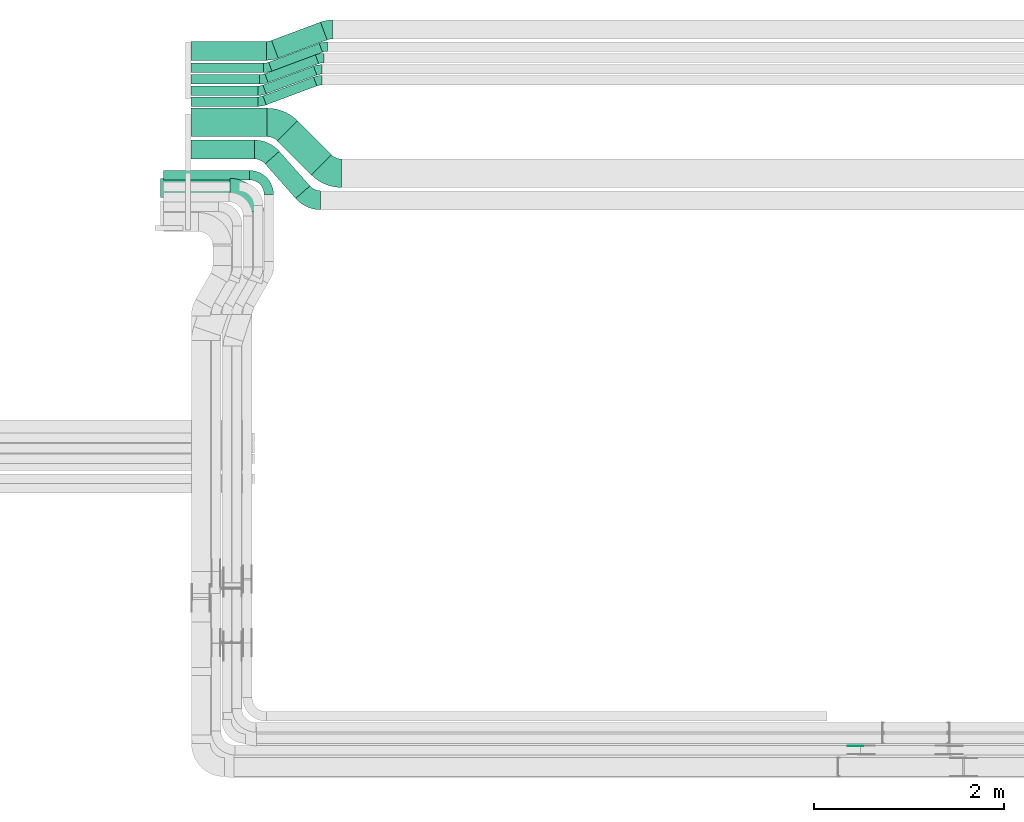
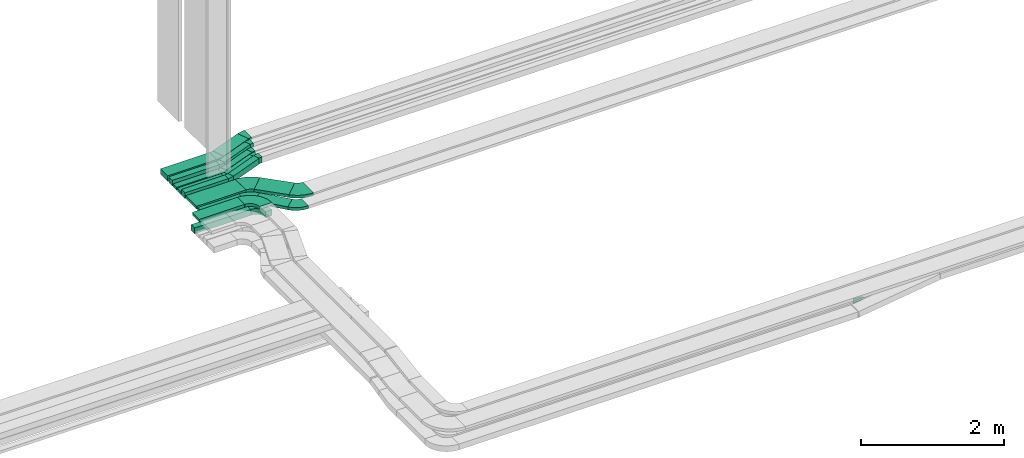
# One storey, part 7 of 31: 17 flow fittings, 16 flow segments.
"""IFC2X3 building model written with IfcOpenShell, lengths in millimetres."""

from ifc_helpers import new_model, entity, si_unit, converted_unit, derived_unit, direction, frame, frame_2d, origin, origin_2d_with_axis, place, context, subcontext, project, spatial, polyline, circle_curve, parameter, trimmed, segment, composite_curve, rectangle, outline, extrude, source, transform, mapped, material, type_object, type_shapes, element, save


model = new_model("IFC2X3")

# Units and contexts
model_context = context("Model", 3, precision=0.01, world=origin(), true_north=direction((6.12303176911189e-17, 1.0)))
body_context = subcontext(model_context, "Body", "Model", "MODEL_VIEW")
ifc_project = project(units=[si_unit("LENGTHUNIT", "METRE", prefix="MILLI"), si_unit("AREAUNIT", "SQUARE_METRE"), si_unit("VOLUMEUNIT", "CUBIC_METRE"), converted_unit("PLANEANGLEUNIT", "DEGREE", entity("IfcRatioMeasure", 0.0174532925199433), si_unit("PLANEANGLEUNIT", "RADIAN"), dimensions=[0, 0, 0, 0, 0, 0, 0]), si_unit("MASSUNIT", "GRAM", prefix="KILO"), derived_unit("MASSDENSITYUNIT", [(si_unit("MASSUNIT", "GRAM", prefix="KILO"), 1), (si_unit("LENGTHUNIT", "METRE"), -3)]), derived_unit("MOMENTOFINERTIAUNIT", [(si_unit("LENGTHUNIT", "METRE"), 4)]), si_unit("TIMEUNIT", "SECOND"), si_unit("FREQUENCYUNIT", "HERTZ"), si_unit("THERMODYNAMICTEMPERATUREUNIT", "DEGREE_CELSIUS"), derived_unit("THERMALTRANSMITTANCEUNIT", [(si_unit("MASSUNIT", "GRAM", prefix="KILO"), 1), (si_unit("THERMODYNAMICTEMPERATUREUNIT", "KELVIN"), -1), (si_unit("TIMEUNIT", "SECOND"), -3)]), derived_unit("VOLUMETRICFLOWRATEUNIT", [(si_unit("LENGTHUNIT", "METRE"), 3), (si_unit("TIMEUNIT", "SECOND"), -1)]), derived_unit("MASSFLOWRATEUNIT", [(si_unit("MASSUNIT", "GRAM", prefix="KILO"), 1), (si_unit("TIMEUNIT", "SECOND"), -1)]), derived_unit("ROTATIONALFREQUENCYUNIT", [(si_unit("TIMEUNIT", "SECOND"), -1)]), si_unit("ELECTRICCURRENTUNIT", "AMPERE"), si_unit("ELECTRICVOLTAGEUNIT", "VOLT"), si_unit("POWERUNIT", "WATT"), si_unit("FORCEUNIT", "NEWTON", prefix="KILO"), si_unit("ILLUMINANCEUNIT", "LUX"), si_unit("LUMINOUSFLUXUNIT", "LUMEN"), si_unit("LUMINOUSINTENSITYUNIT", "CANDELA"), derived_unit("USERDEFINED", [(si_unit("MASSUNIT", "GRAM", prefix="KILO"), -1), (si_unit("LENGTHUNIT", "METRE"), -2), (si_unit("TIMEUNIT", "SECOND"), 3), (si_unit("LUMINOUSFLUXUNIT", "LUMEN"), 1)]), derived_unit("LINEARVELOCITYUNIT", [(si_unit("LENGTHUNIT", "METRE"), 1), (si_unit("TIMEUNIT", "SECOND"), -1)]), si_unit("PRESSUREUNIT", "PASCAL"), derived_unit("USERDEFINED", [(si_unit("LENGTHUNIT", "METRE"), -2), (si_unit("MASSUNIT", "GRAM", prefix="KILO"), 1), (si_unit("TIMEUNIT", "SECOND"), -2)]), derived_unit("LINEARFORCEUNIT", [(si_unit("MASSUNIT", "GRAM", prefix="KILO"), 1), (si_unit("LENGTHUNIT", "METRE"), 1), (si_unit("TIMEUNIT", "SECOND"), -2), (si_unit("LENGTHUNIT", "METRE"), -1)]), derived_unit("PLANARFORCEUNIT", [(si_unit("MASSUNIT", "GRAM", prefix="KILO"), 1), (si_unit("LENGTHUNIT", "METRE"), 1), (si_unit("TIMEUNIT", "SECOND"), -2), (si_unit("LENGTHUNIT", "METRE"), -2)])], contexts=[model_context])

# Site, building, storey
site_placement = place(None, frame((0.0, -0.00077364408347762, 0.0)))
site = spatial("IfcSite", under=ifc_project, at=site_placement, CompositionType="ELEMENT")
building_placement = place(site_placement, origin())
building = spatial("IfcBuilding", under=site, at=building_placement, CompositionType="ELEMENT")
storey_placement = place(building_placement, frame((0.0, 0.0, 15900.0)))
storey = spatial("IfcBuildingStorey", under=building, at=storey_placement, CompositionType="ELEMENT", Elevation=15900.0)

# Flow segments
cable_carrier_segment_type = type_object("IfcCableCarrierSegmentType", PredefinedType="CABLETRAYSEGMENT")
flow_segment_1_placement = place(storey_placement, frame((16530.0002685547, 15404.464091057, 2638.30690596885)))
element("IfcFlowSegment", 1, at=flow_segment_1_placement, inside=storey, type_object=cable_carrier_segment_type, context=body_context, shape_type="SweptSolid", body=[
    extrude(rectangle(XDim=702.872698196628, YDim=99.9999999999989, at=frame_2d((0.0, 1.08357767203415e-12), x_axis=(1.0, 0.0))), frame((351.436349098314, 50.0, 0.0), z_axis=(0.0, 0.0, 1.0), x_axis=(-1.0, 0.0, 0.0)), (0.0, 0.0, 1.0), 50.0000000000016),
])
flow_segment_2_placement = place(storey_placement, frame((16530.0002685547, 15524.464091057, 2638.30690596882)))
element("IfcFlowSegment", 2, at=flow_segment_2_placement, inside=storey, type_object=cable_carrier_segment_type, context=body_context, shape_type="SweptSolid", body=[
    extrude(rectangle(XDim=722.872698196632, YDim=99.9999999999989, at=frame_2d((0.0, 1.08357767203415e-12), x_axis=(1.0, 0.0))), frame((361.436349098316, 50.0, 0.0), z_axis=(0.0, 0.0, 1.0), x_axis=(-1.0, 0.0, 0.0)), (0.0, 0.0, 1.0), 50.0000000000016),
])
flow_segment_3_placement = place(storey_placement, frame((16530.0002685547, 15775.0, 2635.0)))
element("IfcFlowSegment", 3, at=flow_segment_3_placement, inside=storey, type_object=cable_carrier_segment_type, context=body_context, shape_type="SweptSolid", body=[
    extrude(rectangle(XDim=793.840872745794, YDim=199.999999999998, at=frame_2d((0.0, -2.16715534406831e-12), x_axis=(1.0, 0.0))), frame((396.920436372899, 100.0, 0.0), z_axis=(0.0, 0.0, 1.0), x_axis=(-1.0, 0.0, 0.0)), (0.0, 0.0, 1.0), 99.9999999999989),
])
flow_segment_4_placement = place(storey_placement, frame((16530.0002685547, 15645.0, 2635.0)))
element("IfcFlowSegment", 4, at=flow_segment_4_placement, inside=storey, type_object=cable_carrier_segment_type, context=body_context, shape_type="SweptSolid", body=[
    extrude(rectangle(XDim=762.872698196634, YDim=99.9999999999989, at=frame_2d((-1.08002495835535e-12, 0.0), x_axis=(1.0, 0.0))), frame((381.436349098316, 50.0, 0.0), z_axis=(0.0, 0.0, 1.0), x_axis=(-1.0, 0.0, 0.0)), (0.0, 0.0, 1.0), 99.9999999999968),
])
flow_segment_5_placement = place(storey_placement, frame((16530.0002685547, 15290.0, 2635.0)))
element("IfcFlowSegment", 5, at=flow_segment_5_placement, inside=storey, type_object=cable_carrier_segment_type, context=body_context, shape_type="SweptSolid", body=[
    extrude(rectangle(XDim=702.872698196635, YDim=99.9999999999989, at=frame_2d((-1.08002495835535e-12, -1.08357767203415e-12), x_axis=(1.0, 0.0))), frame((351.436349098316, 50.0, 0.0), z_axis=(0.0, 0.0, 1.0), x_axis=(-1.0, 0.0, 0.0)), (0.0, 0.0, 1.0), 99.9999999999989),
])
flow_segment_6_placement = place(storey_placement, frame((16238.5446118447, 14513.9183476424, 2607.25805153974)))
element("IfcFlowSegment", 6, at=flow_segment_6_placement, inside=storey, type_object=cable_carrier_segment_type, context=body_context, shape_type="SweptSolid", body=[
    extrude(rectangle(XDim=908.999999999999, YDim=99.9999999999989, at=frame_2d((-1.08002495835535e-12, 0.0), x_axis=(1.0, 0.0))), frame((454.500000000001, 50.0, 0.0), z_axis=(0.0, 0.0, 1.0), x_axis=(-1.0, 0.0, 0.0)), (0.0, 0.0, 1.0), 99.9999999999989),
])
flow_segment_7_placement = place(storey_placement, frame((16208.5446118446, 14330.1675330991, 2927.25805153973)))
element("IfcFlowSegment", 7, at=flow_segment_7_placement, inside=storey, type_object=cable_carrier_segment_type, context=body_context, shape_type="SweptSolid", body=[
    extrude(rectangle(XDim=733.999999999982, YDim=200.000000000002, at=frame_2d((-1.08002495835535e-12, -1.08713038571295e-12), x_axis=(1.0, 0.0))), frame((367.0, 100.0, 0.0), z_axis=(0.0, 0.0, 1.0), x_axis=(-1.0, 0.0, 0.0)), (0.0, 0.0, 1.0), 50.0000000000016),
])
flow_segment_8_placement = place(storey_placement, frame((17378.2565439903, 15797.468809775, 2635.0)))
element("IfcFlowSegment", 8, at=flow_segment_8_placement, inside=storey, type_object=cable_carrier_segment_type, context=body_context, shape_type="SweptSolid", body=[
    extrude(rectangle(XDim=550.78362976838, YDim=200.000000000002, at=frame_2d((-6.25277607468888e-13, 1.3855583347322e-12), x_axis=(1.0, 0.0))), frame((292.973609567333, 190.028144722384, 0.0), z_axis=(0.0, 0.0, 1.0), x_axis=(-0.936802993017805, -0.349857331312182, 0.0)), (0.0, 0.0, 1.0), 99.9999999999989),
])
flow_segment_9_placement = place(storey_placement, frame((17347.2883694412, 15661.1491090768, 2635.0)))
element("IfcFlowSegment", 9, at=flow_segment_9_placement, inside=storey, type_object=cable_carrier_segment_type, context=body_context, shape_type="SweptSolid", body=[
    extrude(rectangle(XDim=568.84728066999, YDim=100.000000000002, at=frame_2d((-6.53699316899292e-13, 1.3962164757686e-12), x_axis=(1.0, 0.0))), frame((283.941784116463, 146.347845420602, 0.0), z_axis=(0.0, 0.0, 1.0), x_axis=(0.936802993017794, 0.349857331312211, 0.0)), (0.0, 0.0, 1.0), 99.9999999999989),
])
flow_segment_10_placement = place(storey_placement, frame((17307.2883694412, 15540.6132001339, 2638.30690596882)))
element("IfcFlowSegment", 10, at=flow_segment_10_placement, inside=storey, type_object=cable_carrier_segment_type, context=body_context, shape_type="SweptSolid", body=[
    extrude(rectangle(XDim=568.847280669995, YDim=100.0, at=frame_2d((-2.8421709430404e-13, 2.41229258790554e-12), x_axis=(1.0, 0.0))), frame((283.941784116454, 146.347845420595, 0.0), z_axis=(0.0, 0.0, 1.0), x_axis=(0.936802993017794, 0.349857331312212, 0.0)), (0.0, 0.0, 1.0), 50.0000000000016),
])
flow_segment_11_placement = place(storey_placement, frame((17287.2883694412, 15420.6132001339, 2638.30690596885)))
element("IfcFlowSegment", 11, at=flow_segment_11_placement, inside=storey, type_object=cable_carrier_segment_type, context=body_context, shape_type="SweptSolid", body=[
    extrude(rectangle(XDim=568.847280669995, YDim=100.000000000002, at=frame_2d((1.02318153949454e-12, -3.80140363631654e-13), x_axis=(1.0, 0.0))), frame((283.941784116476, 146.347845420606, 0.0), z_axis=(0.0, 0.0, 1.0), x_axis=(0.936802993017794, 0.349857331312212, 0.0)), (0.0, 0.0, 1.0), 50.0000000000016),
])
flow_segment_12_placement = place(storey_placement, frame((17287.2883694412, 15306.1491090768, 2635.0)))
element("IfcFlowSegment", 12, at=flow_segment_12_placement, inside=storey, type_object=cable_carrier_segment_type, context=body_context, shape_type="SweptSolid", body=[
    extrude(rectangle(XDim=568.847280669993, YDim=99.9999999999975, at=frame_2d((1.02318153949454e-12, -3.83693077310454e-13), x_axis=(1.0, 0.0))), frame((283.941784116461, 146.3478454206, 0.0), z_axis=(0.0, 0.0, 1.0), x_axis=(0.936802993017794, 0.349857331312213, 0.0)), (0.0, 0.0, 1.0), 99.9999999999989),
])
flow_segment_13_placement = place(storey_placement, frame((16530.0002685547, 14735.0, 2650.0)))
element("IfcFlowSegment", 13, at=flow_segment_13_placement, inside=storey, type_object=cable_carrier_segment_type, context=body_context, shape_type="SweptSolid", body=[
    extrude(rectangle(XDim=666.306441925909, YDim=199.999999999998, at=origin_2d_with_axis()), frame((333.153220962954, 100.0, 0.0)), (0.0, 0.0, 1.0), 50.0000000000016),
])
flow_segment_14_placement = place(storey_placement, frame((17310.3630313463, 14318.9916344421, 2650.0)))
element("IfcFlowSegment", 14, at=flow_segment_14_placement, inside=storey, type_object=cable_carrier_segment_type, context=body_context, shape_type="SweptSolid", body=[
    extrude(rectangle(XDim=486.584397365072, YDim=200.000000000002, at=frame_2d((-7.53175299905706e-13, -8.10018718766514e-13), x_axis=(1.0, 0.0))), frame((236.04663611616, 248.521119814901, 0.0), z_axis=(0.0, 0.0, 1.0), x_axis=(-0.662237622743354, 0.749293888286319, 0.0)), (0.0, 0.0, 1.0), 50.0000000000016),
])
flow_segment_15_placement = place(storey_placement, frame((17439.5259326507, 14567.5345637612, 2650.0)))
element("IfcFlowSegment", 15, at=flow_segment_15_placement, inside=storey, type_object=cable_carrier_segment_type, context=body_context, shape_type="SweptSolid", body=[
    extrude(rectangle(XDim=506.040043959347, YDim=299.999999999999, at=frame_2d((-7.53175299905706e-13, 7.67386154620908e-13), x_axis=(1.0, 0.0))), frame((284.978190495775, 284.97819049578, 0.0), z_axis=(0.0, 0.0, 1.0), x_axis=(-0.70710678118652, 0.707106781186575, 0.0)), (0.0, 0.0, 1.0), 50.0000000000016),
])
flow_segment_16_placement = place(storey_placement, frame((16530.0002685547, 14970.0, 2650.0)))
element("IfcFlowSegment", 16, at=flow_segment_16_placement, inside=storey, type_object=cable_carrier_segment_type, context=body_context, shape_type="SweptSolid", body=[
    extrude(rectangle(XDim=801.752540136818, YDim=300.000000000001, at=frame_2d((-1.08002495835535e-12, 0.0), x_axis=(1.0, 0.0))), frame((400.876270068412, 150.0, 0.0)), (0.0, 0.0, 1.0), 50.0000000000016),
])

# Flow fittings
ifc_material_1 = material()
cable_carrier_fitting_type_1 = type_object("IfcCableCarrierFittingType", Name="470_DKC_S5_Variable Angle Elbow 0-45:-", PredefinedType="NOTDEFINED", material=ifc_material_1)
shared_shape_1 = source(origin(), body_context, "Body", "SweptSolid", [
    extrude(outline(composite_curve([segment(polyline([(-100.749999999999, -150.250000000001), (-99.7499999999981, -150.250000000001)]), True, "CONTINUOUS"), segment(trimmed(circle_curve(frame_2d((-99.7500000000006, 99.7499999999987), x_axis=(0.0, -1.0)), 250.0), [parameter(0.0)], [parameter(90.0000000000001)], True, "PARAMETER"), True, "CONTINUOUS"), segment(polyline([(150.249999999999, 99.7500000000013), (150.249999999999, 100.750000000001)]), True, "CONTINUOUS"), segment(polyline([(150.249999999999, 100.750000000001), (50.2499999999992, 100.750000000001)]), True, "CONTINUOUS"), segment(polyline([(50.2499999999992, 100.750000000001), (50.2499999999992, 99.7500000000002)]), True, "CONTINUOUS"), segment(trimmed(circle_curve(frame_2d((-99.7500000000006, 99.7499999999987), x_axis=(0.0, -1.0)), 150.0), [parameter(0.0)], [parameter(90.0000000000001)], True, "PARAMETER"), False, "CONTINUOUS"), segment(polyline([(-99.7499999999989, -50.2500000000011), (-100.75, -50.2500000000011)]), True, "CONTINUOUS"), segment(polyline([(-100.75, -50.2500000000011), (-100.749999999999, -150.250000000001)]), True, "CONTINUOUS")], self_intersect=False)), frame((-100.249999999991, 100.249999999992, -50.0)), (0.0, 0.0, 1.0), 100.0),
])
type_shapes(cable_carrier_fitting_type_1, [shared_shape_1])
flow_fitting_1_placement = place(storey_placement, frame((17348.5446118446, 14563.9183476424, 2657.25805153974), z_axis=(0.0, 0.0, 1.0), x_axis=(0.0, 1.0, 0.0)))
element("IfcFlowFitting", 17, at=flow_fitting_1_placement, inside=storey, type_object=cable_carrier_fitting_type_1, material=ifc_material_1, Name="470_DKC_S5_Variable Angle Elbow 0-45:-", ObjectType="470_DKC_S5_Variable Angle Elbow 0-45:-", context=body_context, shape_type="MappedRepresentation", body=[
    mapped(shared_shape_1, transform((0.0, 0.0, 0.0), scale=1.0)),
])
cable_carrier_fitting_type_2 = type_object("IfcCableCarrierFittingType", Name="470_DKC_S5_Variable Angle Elbow 0-45:-", PredefinedType="NOTDEFINED", material=ifc_material_1)
shared_shape_2 = source(origin(), body_context, "Body", "SweptSolid", [
    extrude(outline(composite_curve([segment(polyline([(-125.750000000004, -225.249999999998), (-124.750000000003, -225.249999999998)]), True, "CONTINUOUS"), segment(trimmed(circle_curve(frame_2d((-124.749999999998, 124.750000000002), x_axis=(0.0, -1.0)), 350.0), [parameter(0.0)], [parameter(90.0)], True, "PARAMETER"), True, "CONTINUOUS"), segment(polyline([(225.250000000002, 124.749999999996), (225.250000000002, 125.749999999995)]), True, "CONTINUOUS"), segment(polyline([(225.250000000002, 125.749999999995), (25.2500000000021, 125.750000000001)]), True, "CONTINUOUS"), segment(polyline([(25.2500000000021, 125.750000000001), (25.2500000000021, 124.749999999999)]), True, "CONTINUOUS"), segment(trimmed(circle_curve(frame_2d((-124.749999999998, 124.750000000002), x_axis=(0.0, -1.0)), 150.0), [parameter(0.0)], [parameter(90.0)], True, "PARAMETER"), False, "CONTINUOUS"), segment(polyline([(-124.75, -25.2499999999979), (-125.750000000001, -25.2499999999979)]), True, "CONTINUOUS"), segment(polyline([(-125.750000000001, -25.2499999999979), (-125.750000000004, -225.249999999998)]), True, "CONTINUOUS")], self_intersect=False)), frame((-125.249999999991, 125.249999999992, -25.0)), (0.0, 0.0, 1.0), 50.000000000001),
])
type_shapes(cable_carrier_fitting_type_2, [shared_shape_2])
flow_fitting_2_placement = place(storey_placement, frame((17193.5446118446, 14430.1675330991, 2952.25805153973), z_axis=(0.0, 0.0, 1.0), x_axis=(0.0, 1.0, 0.0)))
element("IfcFlowFitting", 18, at=flow_fitting_2_placement, inside=storey, type_object=cable_carrier_fitting_type_2, material=ifc_material_1, Name="470_DKC_S5_Variable Angle Elbow 0-45:-", ObjectType="470_DKC_S5_Variable Angle Elbow 0-45:-", context=body_context, shape_type="MappedRepresentation", body=[
    mapped(shared_shape_2, transform((0.0, 0.0, 0.0), scale=1.0)),
])
ifc_material_2 = material(Name="G")
cable_carrier_fitting_type_3 = type_object("IfcCableCarrierFittingType", PredefinedType="NOTDEFINED", material=ifc_material_2)
shared_shape_3 = source(origin(), body_context, "Body", "SweptSolid", [
    extrude(outline(composite_curve([segment(trimmed(circle_curve(frame_2d((-41.4651162790697, 0.0), x_axis=(1.0, 0.0)), 25.0), [parameter(90.0000000000007)], [parameter(270.0)], True, "PARAMETER"), True, "CONTINUOUS"), segment(polyline([(-41.4651162790697, -25.0), (-29.9651162790697, -25.0)]), True, "CONTINUOUS"), segment(polyline([(-29.9651162790697, -25.0), (-28.1046511627907, -38.5)]), True, "CONTINUOUS"), segment(polyline([(-28.1046511627907, -38.5), (99.5348837209303, -38.5)]), True, "CONTINUOUS"), segment(polyline([(99.5348837209303, -38.5), (99.5348837209303, 38.5)]), True, "CONTINUOUS"), segment(polyline([(99.5348837209303, 38.5), (-28.1046511627907, 38.5)]), True, "CONTINUOUS"), segment(polyline([(-28.1046511627907, 38.5), (-29.9651162790697, 25.0)]), True, "CONTINUOUS"), segment(polyline([(-29.9651162790697, 25.0), (-41.46511627907, 25.0)]), True, "CONTINUOUS")], self_intersect=False)), frame((41.4651162790697, 0.0, 0.0), z_axis=(0.0, 0.0, -1.0), x_axis=(1.0, 0.0, 0.0)), (0.0, 0.0, -1.0), 2.0),
])
type_shapes(cable_carrier_fitting_type_3, [shared_shape_3])
flow_fitting_3_placement = place(storey_placement, frame((23591.0471184485, 8548.42624586808, 2550.0), z_axis=(0.0, 1.0, 0.0), x_axis=(-1.0, 0.0, 0.0)))
element("IfcFlowFitting", 19, at=flow_fitting_3_placement, inside=storey, type_object=cable_carrier_fitting_type_3, material=ifc_material_2, context=body_context, shape_type="MappedRepresentation", body=[
    mapped(shared_shape_3, transform((0.0, 0.0, 0.0), scale=1.0)),
])
cable_carrier_fitting_type_4 = type_object("IfcCableCarrierFittingType", Name="470_DKC_S5_Variable Angle Elbow 0-45:-", PredefinedType="NOTDEFINED", material=ifc_material_1)
shared_shape_4 = source(origin(), body_context, "Body", "SweptSolid", [
    extrude(outline(composite_curve([segment(polyline([(-44.7163671622733, -107.987090205601), (-43.7163671622719, -107.987090205601)]), True, "CONTINUOUS"), segment(trimmed(circle_curve(frame_2d((-43.7163671622725, 242.012909794399), x_axis=(0.0, -1.0)), 350.0), [parameter(0.0)], [parameter(20.4785891112335)], True, "PARAMETER"), True, "CONTINUOUS"), segment(polyline([(78.7336987969777, -85.8681377618374), (79.6705017899953, -85.5182804305254)]), True, "CONTINUOUS"), segment(polyline([(79.6705017899953, -85.5182804305254), (9.69903552756711, 101.842318173039)]), True, "CONTINUOUS"), segment(polyline([(9.69903552756709, 101.842318173039), (8.76223253454902, 101.492460841726)]), True, "CONTINUOUS"), segment(trimmed(circle_curve(frame_2d((-43.7163671622725, 242.012909794399), x_axis=(0.0, -1.0)), 150.0), [parameter(0.0)], [parameter(20.4785891112335)], True, "PARAMETER"), False, "CONTINUOUS"), segment(polyline([(-43.7163671622719, 92.0129097943993), (-44.7163671622733, 92.0129097943993)]), True, "CONTINUOUS"), segment(polyline([(-44.7163671622733, 92.0129097943993), (-44.7163671622733, -107.987090205601)]), True, "CONTINUOUS")], self_intersect=False)), frame((-1.44276009193253, 7.98709020559252, -50.0)), (0.0, 0.0, 1.0), 100.0),
])
type_shapes(cable_carrier_fitting_type_4, [shared_shape_4])
flow_fitting_4_placement = place(storey_placement, frame((17972.4600385607, 16099.9939089948, 2685.0), z_axis=(0.0, 0.0, 1.0), x_axis=(-1.0, 0.0, 0.0)))
element("IfcFlowFitting", 20, at=flow_fitting_4_placement, inside=storey, type_object=cable_carrier_fitting_type_4, material=ifc_material_1, Name="470_DKC_S5_Variable Angle Elbow 0-45:-", ObjectType="470_DKC_S5_Variable Angle Elbow 0-45:-", context=body_context, shape_type="MappedRepresentation", body=[
    mapped(shared_shape_4, transform((0.0, 0.0, 0.0), scale=1.0)),
])
flow_fitting_5_placement = place(storey_placement, frame((17370.0002685547, 15875.0, 2685.0)))
element("IfcFlowFitting", 21, at=flow_fitting_5_placement, inside=storey, type_object=cable_carrier_fitting_type_4, material=ifc_material_1, Name="470_DKC_S5_Variable Angle Elbow 0-45:-", ObjectType="470_DKC_S5_Variable Angle Elbow 0-45:-", context=body_context, shape_type="MappedRepresentation", body=[
    mapped(shared_shape_4, transform((0.0, 0.0, 0.0), scale=1.0)),
])
cable_carrier_fitting_type_5 = type_object("IfcCableCarrierFittingType", Name="470_DKC_S5_Variable Angle Elbow 0-45:-", PredefinedType="NOTDEFINED", material=ifc_material_1)
shared_shape_5 = source(origin(), body_context, "Body", "SweptSolid", [
    extrude(outline(composite_curve([segment(polyline([(-35.9699338794728, -56.4071650310477), (-34.9699338794715, -56.4071650310477)]), True, "CONTINUOUS"), segment(trimmed(circle_curve(frame_2d((-34.9699338794741, 193.592834968952), x_axis=(0.0, -1.0)), 250.0), [parameter(0.0)], [parameter(20.4785891112358)], True, "PARAMETER"), True, "CONTINUOUS"), segment(polyline([(52.4943989485728, -40.6079132854985), (53.4312019415904, -40.2580559541864)]), True, "CONTINUOUS"), segment(polyline([(53.4312019415904, -40.2580559541864), (18.445468810372, 53.422243347594)]), True, "CONTINUOUS"), segment(polyline([(18.4454688103721, 53.422243347594), (17.508665817354, 53.0723860162817)]), True, "CONTINUOUS"), segment(trimmed(circle_curve(frame_2d((-34.9699338794741, 193.592834968952), x_axis=(0.0, -1.0)), 150.0), [parameter(0.0)], [parameter(20.4785891112358)], True, "PARAMETER"), False, "CONTINUOUS"), segment(polyline([(-34.9699338794724, 43.5928349689522), (-35.9699338794737, 43.5928349689522)]), True, "CONTINUOUS"), segment(polyline([(-35.9699338794737, 43.5928349689522), (-35.9699338794728, -56.4071650310477)]), True, "CONTINUOUS")], self_intersect=False)), frame((-1.15736792389365, 6.40716503103935, -50.0)), (0.0, 0.0, 1.0), 100.0),
])
type_shapes(cable_carrier_fitting_type_5, [shared_shape_5])
flow_fitting_6_placement = place(storey_placement, frame((17330.0002685547, 15695.0, 2685.0)))
element("IfcFlowFitting", 22, at=flow_fitting_6_placement, inside=storey, type_object=cable_carrier_fitting_type_5, material=ifc_material_1, Name="470_DKC_S5_Variable Angle Elbow 0-45:-", ObjectType="470_DKC_S5_Variable Angle Elbow 0-45:-", context=body_context, shape_type="MappedRepresentation", body=[
    mapped(shared_shape_5, transform((0.0, 0.0, 0.0), scale=1.0)),
])
flow_fitting_7_placement = place(storey_placement, frame((17932.4600385606, 15919.9939089948, 2685.0), z_axis=(0.0, 0.0, 1.0), x_axis=(-1.0, 0.0, 0.0)))
element("IfcFlowFitting", 23, at=flow_fitting_7_placement, inside=storey, type_object=cable_carrier_fitting_type_5, material=ifc_material_1, Name="470_DKC_S5_Variable Angle Elbow 0-45:-", ObjectType="470_DKC_S5_Variable Angle Elbow 0-45:-", context=body_context, shape_type="MappedRepresentation", body=[
    mapped(shared_shape_5, transform((0.0, 0.0, 0.0), scale=1.0)),
])
flow_fitting_8_placement = place(storey_placement, frame((17270.0002685547, 15340.0, 2685.0)))
element("IfcFlowFitting", 24, at=flow_fitting_8_placement, inside=storey, type_object=cable_carrier_fitting_type_5, material=ifc_material_1, Name="470_DKC_S5_Variable Angle Elbow 0-45:-", ObjectType="470_DKC_S5_Variable Angle Elbow 0-45:-", context=body_context, shape_type="MappedRepresentation", body=[
    mapped(shared_shape_5, transform((0.0, 0.0, 0.0), scale=1.0)),
])
flow_fitting_9_placement = place(storey_placement, frame((17872.4600385606, 15564.9939089948, 2685.0), z_axis=(0.0, 0.0, 1.0), x_axis=(-1.0, 0.0, 0.0)))
element("IfcFlowFitting", 25, at=flow_fitting_9_placement, inside=storey, type_object=cable_carrier_fitting_type_5, material=ifc_material_1, Name="470_DKC_S5_Variable Angle Elbow 0-45:-", ObjectType="470_DKC_S5_Variable Angle Elbow 0-45:-", context=body_context, shape_type="MappedRepresentation", body=[
    mapped(shared_shape_5, transform((0.0, 0.0, 0.0), scale=1.0)),
])
cable_carrier_fitting_type_6 = type_object("IfcCableCarrierFittingType", Name="470_DKC_S5_Variable Angle Elbow 0-45:-", PredefinedType="NOTDEFINED", material=ifc_material_1)
shared_shape_6 = source(origin(), body_context, "Body", "SweptSolid", [
    extrude(outline(composite_curve([segment(polyline([(-35.9699338794733, -56.4071650310474), (-34.969933879472, -56.4071650310474)]), True, "CONTINUOUS"), segment(trimmed(circle_curve(frame_2d((-34.9699338794725, 193.592834968952), x_axis=(0.0, -1.0)), 250.0), [parameter(0.0)], [parameter(20.4785891112358)], True, "PARAMETER"), True, "CONTINUOUS"), segment(polyline([(52.4943989485725, -40.6079132854989), (53.4312019415902, -40.2580559541868)]), True, "CONTINUOUS"), segment(polyline([(53.4312019415902, -40.2580559541868), (18.4454688103725, 53.4222433475938)]), True, "CONTINUOUS"), segment(polyline([(18.4454688103725, 53.4222433475938), (17.5086658173545, 53.0723860162815)]), True, "CONTINUOUS"), segment(trimmed(circle_curve(frame_2d((-34.9699338794725, 193.592834968952), x_axis=(0.0, -1.0)), 150.0), [parameter(0.0)], [parameter(20.4785891112358)], True, "PARAMETER"), False, "CONTINUOUS"), segment(polyline([(-34.969933879472, 43.5928349689524), (-35.9699338794733, 43.5928349689524)]), True, "CONTINUOUS"), segment(polyline([(-35.9699338794733, 43.5928349689524), (-35.9699338794733, -56.4071650310474)]), True, "CONTINUOUS")], self_intersect=False)), frame((-1.15736792389367, 6.40716503103937, -25.0)), (0.0, 0.0, 1.0), 50.0000000000001),
])
type_shapes(cable_carrier_fitting_type_6, [shared_shape_6])
flow_fitting_10_placement = place(storey_placement, frame((17290.0002685547, 15574.4640910571, 2663.30690596885)))
element("IfcFlowFitting", 26, at=flow_fitting_10_placement, inside=storey, type_object=cable_carrier_fitting_type_6, material=ifc_material_1, Name="470_DKC_S5_Variable Angle Elbow 0-45:-", ObjectType="470_DKC_S5_Variable Angle Elbow 0-45:-", context=body_context, shape_type="MappedRepresentation", body=[
    mapped(shared_shape_6, transform((0.0, 0.0, 0.0), scale=1.0)),
])
flow_fitting_11_placement = place(storey_placement, frame((17892.4600385606, 15799.458000052, 2663.30690596881), z_axis=(0.0, 0.0, 1.0), x_axis=(-1.0, 0.0, 0.0)))
element("IfcFlowFitting", 27, at=flow_fitting_11_placement, inside=storey, type_object=cable_carrier_fitting_type_6, material=ifc_material_1, Name="470_DKC_S5_Variable Angle Elbow 0-45:-", ObjectType="470_DKC_S5_Variable Angle Elbow 0-45:-", context=body_context, shape_type="MappedRepresentation", body=[
    mapped(shared_shape_6, transform((0.0, 0.0, 0.0), scale=1.0)),
])
flow_fitting_12_placement = place(storey_placement, frame((17270.0002685547, 15454.464091057, 2663.30690596885)))
element("IfcFlowFitting", 28, at=flow_fitting_12_placement, inside=storey, type_object=cable_carrier_fitting_type_6, material=ifc_material_1, Name="470_DKC_S5_Variable Angle Elbow 0-45:-", ObjectType="470_DKC_S5_Variable Angle Elbow 0-45:-", context=body_context, shape_type="MappedRepresentation", body=[
    mapped(shared_shape_6, transform((0.0, 0.0, 0.0), scale=1.0)),
])
flow_fitting_13_placement = place(storey_placement, frame((17872.4600385606, 15679.4580000519, 2663.30690596911), z_axis=(0.0, 0.0, 1.0), x_axis=(-1.0, 0.0, 0.0)))
element("IfcFlowFitting", 29, at=flow_fitting_13_placement, inside=storey, type_object=cable_carrier_fitting_type_6, material=ifc_material_1, Name="470_DKC_S5_Variable Angle Elbow 0-45:-", ObjectType="470_DKC_S5_Variable Angle Elbow 0-45:-", context=body_context, shape_type="MappedRepresentation", body=[
    mapped(shared_shape_6, transform((0.0, 0.0, 0.0), scale=1.0)),
])
cable_carrier_fitting_type_7 = type_object("IfcCableCarrierFittingType", Name="470_DKC_S5_Variable Angle Elbow 0-45:-", PredefinedType="NOTDEFINED", material=ifc_material_1)
shared_shape_7 = source(origin(), body_context, "Body", "SweptSolid", [
    extrude(outline(composite_curve([segment(polyline([(-94.5772954414768, -142.407620629148), (-93.5772954414754, -142.407620629148)]), True, "CONTINUOUS"), segment(trimmed(circle_curve(frame_2d((-93.5772954414701, 207.592379370851), x_axis=(0.0, -1.0)), 350.0), [parameter(0.0)], [parameter(48.5292492852141)], True, "PARAMETER"), True, "CONTINUOUS"), segment(polyline([(168.675565458731, -24.1907885893336), (169.337803081474, -23.4414947010479)]), True, "CONTINUOUS"), segment(polyline([(169.337803081474, -23.4414947010479), (19.4790254242174, 109.006029847631)]), True, "CONTINUOUS"), segment(polyline([(19.4790254242174, 109.00602984763), (18.8167878014734, 108.256735959344)]), True, "CONTINUOUS"), segment(trimmed(circle_curve(frame_2d((-93.5772954414701, 207.592379370851), x_axis=(0.0, -1.0)), 150.0), [parameter(0.0)], [parameter(48.5292492852141)], True, "PARAMETER"), False, "CONTINUOUS"), segment(polyline([(-93.577295441472, 57.5923793708516), (-94.5772954414734, 57.5923793708516)]), True, "CONTINUOUS"), segment(polyline([(-94.5772954414734, 57.5923793708516), (-94.5772954414768, -142.407620629148)]), True, "CONTINUOUS")], self_intersect=False)), frame((-19.1162626326129, 42.4076206291418, -25.0)), (0.0, 0.0, 1.0), 50.0000000000008),
])
type_shapes(cable_carrier_fitting_type_7, [shared_shape_7])
for number, where, z_axis, x_axis, name in (
    (30, (17782.8190663702, 14300.025508514, 2675.0), (0.0, 0.0, 1.0), (0.662237622743367, -0.749293888286308, 0.0), "470_DKC_S5_Variable Angle Elbow 0-45:-"),
    (31, (17310.0002685547, 14835.0, 2675.0), (0.0, 0.0, 1.0), (-0.662237622743354, 0.749293888286319, 0.0), "470_DKC_S5_Variable Angle Elbow 0-45:-"),
):
    element("IfcFlowFitting", number, at=place(storey_placement, frame(where, z_axis=z_axis, x_axis=x_axis)), inside=storey, type_object=cable_carrier_fitting_type_7, material=ifc_material_1, Name=name, ObjectType="470_DKC_S5_Variable Angle Elbow 0-45:-", context=body_context, shape_type="MappedRepresentation", body=[
        mapped(shared_shape_7, transform((0.0, 0.0, 0.0), scale=1.0)),
    ])
cable_carrier_fitting_type_8 = type_object("IfcCableCarrierFittingType", Name="470_DKC_S5_Variable Angle Elbow 0-45:-", PredefinedType="NOTDEFINED", material=ifc_material_1)
shared_shape_8 = source(origin(), body_context, "Body", "SweptSolid", [
    extrude(outline(composite_curve([segment(polyline([(-106.992793873276, -194.110759517316), (-105.992793873275, -194.110759517316)]), True, "CONTINUOUS"), segment(trimmed(circle_curve(frame_2d((-105.992793873283, 255.889240482683), x_axis=(0.0, -1.0)), 450.0), [parameter(0.0)], [parameter(45.0)], True, "PARAMETER"), True, "CONTINUOUS"), segment(polyline([(212.205257660669, -62.3088110512572), (212.912364441855, -61.6017042700708)]), True, "CONTINUOUS"), segment(polyline([(212.912364441855, -61.6017042700708), (0.780330085887347, 150.53033008589)]), True, "CONTINUOUS"), segment(polyline([(0.780330085887396, 150.53033008589), (0.0732233047007628, 149.823223304703)]), True, "CONTINUOUS"), segment(trimmed(circle_curve(frame_2d((-105.992793873283, 255.889240482683), x_axis=(0.0, -1.0)), 150.0), [parameter(0.0)], [parameter(45.0)], True, "PARAMETER"), False, "CONTINUOUS"), segment(polyline([(-105.99279387328, 105.889240482684), (-106.992793873281, 105.889240482684)]), True, "CONTINUOUS"), segment(polyline([(-106.992793873281, 105.889240482684), (-106.992793873276, -194.110759517316)]), True, "CONTINUOUS")], self_intersect=False)), frame((-18.27127483864, 44.1107595173065, -25.0)), (0.0, 0.0, 1.0), 49.9999999999982),
])
type_shapes(cable_carrier_fitting_type_8, [shared_shape_8])
for number, where, z_axis, x_axis, name in (
    (32, (17991.9913688895, 14585.025508514, 2675.0), (0.0, 0.0, 1.0), (0.707106781186545, -0.70710678118655, 0.0), "470_DKC_S5_Variable Angle Elbow 0-45:-"),
    (33, (17457.0168774035, 15120.0, 2675.0), (0.0, 0.0, 1.0), (-0.70710678118652, 0.707106781186575, 0.0), "470_DKC_S5_Variable Angle Elbow 0-45:-"),
):
    element("IfcFlowFitting", number, at=place(storey_placement, frame(where, z_axis=z_axis, x_axis=x_axis)), inside=storey, type_object=cable_carrier_fitting_type_8, material=ifc_material_1, Name=name, ObjectType="470_DKC_S5_Variable Angle Elbow 0-45:-", context=body_context, shape_type="MappedRepresentation", body=[
        mapped(shared_shape_8, transform((0.0, 0.0, 0.0), scale=1.0)),
    ])

save(model, "model.ifc")
